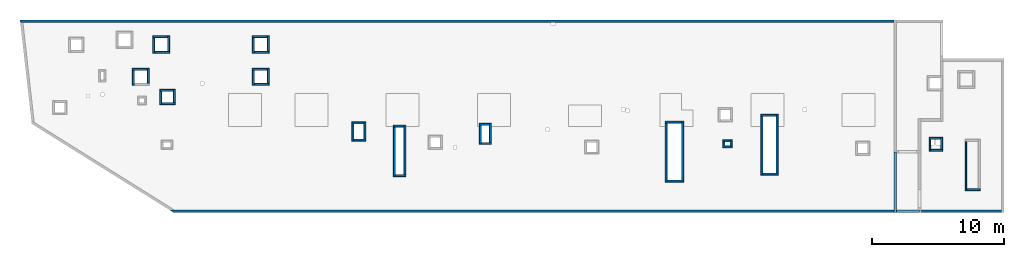
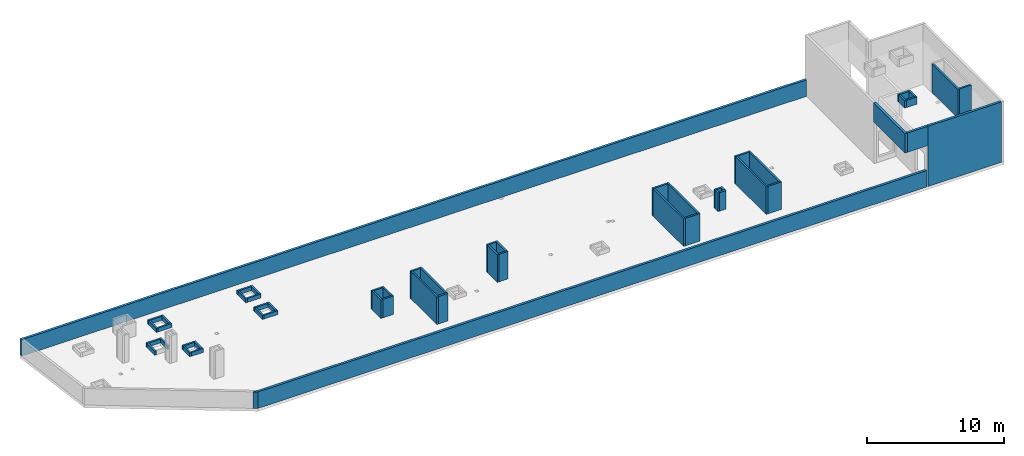
# One storey, part 2 of 3: 54 walls.
"""IFC4 building model written with IfcOpenShell, lengths in millimetres."""

import ifcopenshell
import ifcopenshell.guid

model = None  # the IFC model being written
_history = None  # IfcOwnerHistory: only IFC2X3 demands one
_inside = {}  # id of a spatial element -> (the spatial element, [elements in it])
_under = {}  # id of a project, library or spatial element -> (it, [spatial elements below it])
_declared = {}  # id of a project -> (the project, [libraries it declares])
_typed = {}  # id of a type object -> (the type object, [elements of that type])
_made_of = {}  # id of a material, layer set ... -> (it, [elements and type objects made of it])


def new_model(schema):
    """Start an empty IFC model of exactly this schema.

    Asked for "IFC4X3", IfcOpenShell would pick the latest addendum, in which some entities
    have other attributes; the version numbers below select the first issue.
    IFC2X3 requires an IfcOwnerHistory on every rooted entity: one is made here for all.
    """
    global model, _history
    if schema == "IFC4X3":
        model = ifcopenshell.file(schema_version=(4, 3, 0, 0))
    else:
        model = ifcopenshell.file(schema=schema)
    _inside.clear()
    _under.clear()
    _declared.clear()
    _typed.clear()
    _made_of.clear()
    _history = None
    if model.schema == "IFC2X3":
        org = make("IfcOrganization", Name="unknown")
        user = make(
            "IfcPersonAndOrganization",
            ThePerson=make("IfcPerson", FamilyName="unknown"),
            TheOrganization=org,
        )
        app = make(
            "IfcApplication",
            ApplicationDeveloper=org,
            Version="unknown",
            ApplicationFullName="unknown",
            ApplicationIdentifier="unknown",
        )
        _history = make(
            "IfcOwnerHistory",
            OwningUser=user,
            OwningApplication=app,
            ChangeAction="ADDED",
            CreationDate=0,
        )
    return model


def make(cls, **values):
    """One entity of the class cls with the attributes given. An attribute that is None is left unset."""
    return model.create_entity(
        cls, **{name: value for name, value in values.items() if value is not None}
    )


def entity(cls, *values):
    """Any entity or typed value of the class cls, its attributes in the order of the schema. None: left unset."""
    e = model.create_entity(cls)
    for i, value in enumerate(values):
        if value is not None:
            e[i] = value
    return e


def rooted(cls, **values):
    """An entity with a GlobalId (a new one), such as an element, a storey or a relation."""
    return make(cls, GlobalId=ifcopenshell.guid.new(), OwnerHistory=_history, **values)


def si_unit(unit_type, name, prefix=None):
    """IfcSIUnit, for example si_unit("LENGTHUNIT", "METRE", prefix="MILLI")."""
    return make("IfcSIUnit", UnitType=unit_type, Prefix=prefix, Name=name)


def converted_unit(unit_type, name, factor, base, dimensions=None, offset=None):
    """IfcConversionBasedUnit, such as the inch: factor (a typed value) times the base unit."""
    return make(
        "IfcConversionBasedUnit"
        if offset is None
        else "IfcConversionBasedUnitWithOffset",
        ConversionOffset=offset,
        Dimensions=None
        if dimensions is None
        else entity("IfcDimensionalExponents", *dimensions),
        UnitType=unit_type,
        Name=name,
        ConversionFactor=make(
            "IfcMeasureWithUnit", ValueComponent=factor, UnitComponent=base
        ),
    )


def derived_unit(unit_type, elements):
    """IfcDerivedUnit: a product of units, each with its exponent."""
    return make(
        "IfcDerivedUnit",
        Elements=[
            make("IfcDerivedUnitElement", Unit=unit, Exponent=power)
            for unit, power in elements
        ],
        UnitType=unit_type,
    )


def assignment(units):
    """IfcUnitAssignment: the units of a project."""
    return None if units is None else make("IfcUnitAssignment", Units=units)


def point(xyz):
    """IfcCartesianPoint."""
    return None if xyz is None else make("IfcCartesianPoint", Coordinates=xyz)


def direction(xyz):
    """IfcDirection."""
    return None if xyz is None else make("IfcDirection", DirectionRatios=xyz)


def frame(location, z_axis=None, x_axis=None):
    """IfcAxis2Placement3D, a coordinate frame: its origin and axes. An axis left out is left unset."""
    return make(
        "IfcAxis2Placement3D",
        Location=point(location),
        Axis=direction(z_axis),
        RefDirection=direction(x_axis),
    )


def origin():
    """The frame at (0, 0, 0) with its axes left unset."""
    return frame((0.0, 0.0, 0.0))


def place(relative_to, where):
    """IfcLocalPlacement: puts the frame where relative to a parent placement (None: the world)."""
    return make(
        "IfcLocalPlacement", PlacementRelTo=relative_to, RelativePlacement=where
    )


def context(
    kind, dimensions, precision=None, world=None, true_north=None, identifier=None
):
    """IfcGeometricRepresentationContext, for example the 3D "Model" context."""
    return make(
        "IfcGeometricRepresentationContext",
        ContextIdentifier=identifier,
        ContextType=kind,
        CoordinateSpaceDimension=dimensions,
        Precision=precision,
        WorldCoordinateSystem=world,
        TrueNorth=true_north,
    )


def subcontext(parent, identifier, kind, view, scale=None):
    """IfcGeometricRepresentationSubContext, for example "Body" below "Model"."""
    return make(
        "IfcGeometricRepresentationSubContext",
        ContextIdentifier=identifier,
        ContextType=kind,
        ParentContext=parent,
        TargetScale=scale,
        TargetView=view,
    )


def project(units=None, contexts=None):
    """IfcProject with its units and contexts."""
    return rooted(
        "IfcProject",
        Name="project",
        RepresentationContexts=contexts,
        UnitsInContext=assignment(units),
    )


def spatial(cls, under=None, at=None, **own):
    """A site, building, storey or space (cls), placed at a placement, below another one or the project."""
    s = rooted(cls, ObjectPlacement=at, **own)
    if under is not None:
        _under.setdefault(under.id(), (under, []))[1].append(s)
    return s


def point_list(points):
    """IfcCartesianPointList2D or 3D."""
    cls = (
        "IfcCartesianPointList2D" if len(points[0]) == 2 else "IfcCartesianPointList3D"
    )
    return make(cls, CoordList=points)


def indexed_curve(points, segments=None, self_intersect=None):
    """IfcIndexedPolyCurve: lines and arcs through numbered points (the first is 1)."""
    return make(
        "IfcIndexedPolyCurve",
        Points=point_list(points),
        Segments=segments,
        SelfIntersect=self_intersect,
    )


def outline(outer, holes=None, kind="AREA"):
    """IfcArbitraryClosedProfileDef: a profile drawn as a closed curve; with holes, ...WithVoids."""
    if holes is None:
        return make("IfcArbitraryClosedProfileDef", ProfileType=kind, OuterCurve=outer)
    return make(
        "IfcArbitraryProfileDefWithVoids",
        ProfileType=kind,
        OuterCurve=outer,
        InnerCurves=holes,
    )


def extrude(swept, where, along, depth):
    """IfcExtrudedAreaSolid: the profile swept, set in the frame where, extruded along a direction by depth."""
    return make(
        "IfcExtrudedAreaSolid",
        SweptArea=swept,
        Position=where,
        ExtrudedDirection=direction(along),
        Depth=depth,
    )


def shape(context_of_items, identifier, shape_type, items):
    """IfcShapeRepresentation: the items that make up one representation, for example the "Body"."""
    return make(
        "IfcShapeRepresentation",
        ContextOfItems=context_of_items,
        RepresentationIdentifier=identifier,
        RepresentationType=shape_type,
        Items=items,
    )


def material(Name=None, Category=None):
    """IfcMaterial."""
    return make("IfcMaterial", Name=Name, Category=Category)


def made_of(thing, what):
    """Note that an element or type object is made of a material, layer set ...; save() writes the relation."""
    if what is not None:
        _made_of.setdefault(what.id(), (what, []))[1].append(thing)
    return thing


def type_object(cls, material=None, **own):
    """A type object (cls), such as IfcWallType, which elements share."""
    return made_of(rooted(cls, **own), material)


def element(
    cls,
    number,
    at=None,
    inside=None,
    cuts=None,
    type_object=None,
    material=None,
    context=None,
    identifier="Body",
    shape_type=None,
    held_by="IfcProductDefinitionShape",
    body=None,
    shapes=None,
    **own,
):
    """One element of the class cls, such as IfcWall. Its Tag is "e" and its number.

    at: its placement. inside: the storey or other place that contains it. cuts: it is an
    opening in that element (IfcRelVoidsElement). A single representation is given by context,
    identifier, shape_type and body (its items); several are given by shapes. held_by: the class
    of the entity that holds the representations. save() writes the other relations.
    """
    e = rooted(cls, Tag="e%d" % number, ObjectPlacement=at, **own)
    if body is not None:
        shapes = [shape(context, identifier, shape_type, body)]
    if shapes is not None:
        e.Representation = make(held_by, Representations=shapes)
    if inside is not None:
        _inside.setdefault(inside.id(), (inside, []))[1].append(e)
    if cuts is not None:
        rooted(
            "IfcRelVoidsElement", RelatingBuildingElement=cuts, RelatedOpeningElement=e
        )
    if type_object is not None:
        _typed.setdefault(type_object.id(), (type_object, []))[1].append(e)
    return made_of(e, material)


def aggregate(whole, parts):
    """IfcRelAggregates: a whole, such as a stair, and the parts it consists of."""
    return rooted("IfcRelAggregates", RelatingObject=whole, RelatedObjects=parts)


def save(model, path):
    """Write the relations noted so far, then the file.

    IfcRelAggregates (storeys below a building ...), IfcRelContainedInSpatialStructure (elements
    in a storey), IfcRelDefinesByType, IfcRelAssociatesMaterial and IfcRelDeclares: one each for
    every whole, place, type object, material and project.
    """
    for whole, parts in _under.values():
        aggregate(whole, parts)
    for where, things in _inside.values():
        rooted(
            "IfcRelContainedInSpatialStructure",
            RelatedElements=things,
            RelatingStructure=where,
        )
    for kind, things in _typed.values():
        rooted("IfcRelDefinesByType", RelatedObjects=things, RelatingType=kind)
    for what, things in _made_of.values():
        rooted("IfcRelAssociatesMaterial", RelatedObjects=things, RelatingMaterial=what)
    for by, libraries in _declared.values():
        rooted("IfcRelDeclares", RelatingContext=by, RelatedDefinitions=libraries)
    model.write(path)


model = new_model("IFC4")

# Units and contexts
model_context = context("Model", 3, precision=0.01, world=origin(), true_north=direction((6.12303176911189e-17, 1.0)))
plan_context = context("Plan", 3, precision=0.01, world=origin(), true_north=direction((6.12303176911189e-17, 1.0)))
body_context = subcontext(model_context, "Body", "Model", "MODEL_VIEW")
ifc_project = project(units=[si_unit("LENGTHUNIT", "METRE", prefix="MILLI"), si_unit("AREAUNIT", "SQUARE_METRE"), si_unit("VOLUMEUNIT", "CUBIC_METRE"), converted_unit("PLANEANGLEUNIT", "DEGREE", entity("IfcRatioMeasure", 0.0174532925199433), si_unit("PLANEANGLEUNIT", "RADIAN"), dimensions=[0, 0, 0, 0, 0, 0, 0]), si_unit("MASSUNIT", "GRAM", prefix="KILO"), derived_unit("MASSDENSITYUNIT", [(si_unit("MASSUNIT", "GRAM", prefix="KILO"), 1), (si_unit("LENGTHUNIT", "METRE"), -3)]), derived_unit("MOMENTOFINERTIAUNIT", [(si_unit("LENGTHUNIT", "METRE"), 4)]), si_unit("TIMEUNIT", "SECOND"), si_unit("FREQUENCYUNIT", "HERTZ"), si_unit("THERMODYNAMICTEMPERATUREUNIT", "DEGREE_CELSIUS"), derived_unit("THERMALTRANSMITTANCEUNIT", [(si_unit("MASSUNIT", "GRAM", prefix="KILO"), 1), (si_unit("THERMODYNAMICTEMPERATUREUNIT", "KELVIN"), -1), (si_unit("TIMEUNIT", "SECOND"), -3)]), derived_unit("VOLUMETRICFLOWRATEUNIT", [(si_unit("LENGTHUNIT", "METRE"), 3), (si_unit("TIMEUNIT", "SECOND"), -1)]), derived_unit("MASSFLOWRATEUNIT", [(si_unit("MASSUNIT", "GRAM", prefix="KILO"), 1), (si_unit("TIMEUNIT", "SECOND"), -1)]), derived_unit("ROTATIONALFREQUENCYUNIT", [(si_unit("TIMEUNIT", "SECOND"), -1)]), si_unit("ELECTRICCURRENTUNIT", "AMPERE"), si_unit("ELECTRICVOLTAGEUNIT", "VOLT"), si_unit("POWERUNIT", "WATT"), si_unit("FORCEUNIT", "NEWTON", prefix="KILO"), si_unit("ILLUMINANCEUNIT", "LUX"), si_unit("LUMINOUSFLUXUNIT", "LUMEN"), si_unit("LUMINOUSINTENSITYUNIT", "CANDELA"), derived_unit("USERDEFINED", [(si_unit("MASSUNIT", "GRAM", prefix="KILO"), -1), (si_unit("LENGTHUNIT", "METRE"), -2), (si_unit("TIMEUNIT", "SECOND"), 3), (si_unit("LUMINOUSFLUXUNIT", "LUMEN"), 1)]), derived_unit("LINEARVELOCITYUNIT", [(si_unit("LENGTHUNIT", "METRE"), 1), (si_unit("TIMEUNIT", "SECOND"), -1)]), si_unit("PRESSUREUNIT", "PASCAL"), derived_unit("USERDEFINED", [(si_unit("LENGTHUNIT", "METRE"), -2), (si_unit("MASSUNIT", "GRAM", prefix="KILO"), 1), (si_unit("TIMEUNIT", "SECOND"), -2)]), derived_unit("LINEARFORCEUNIT", [(si_unit("MASSUNIT", "GRAM", prefix="KILO"), 1), (si_unit("LENGTHUNIT", "METRE"), 1), (si_unit("TIMEUNIT", "SECOND"), -2), (si_unit("LENGTHUNIT", "METRE"), -1)]), derived_unit("PLANARFORCEUNIT", [(si_unit("MASSUNIT", "GRAM", prefix="KILO"), 1), (si_unit("LENGTHUNIT", "METRE"), 1), (si_unit("TIMEUNIT", "SECOND"), -2), (si_unit("LENGTHUNIT", "METRE"), -2)])], contexts=[model_context, plan_context])

# Site, building, storey
site_placement = place(None, origin())
site = spatial("IfcSite", under=ifc_project, at=site_placement, CompositionType="ELEMENT")
building_placement = place(site_placement, origin())
building = spatial("IfcBuilding", under=site, at=building_placement, CompositionType="ELEMENT")
storey_placement = place(building_placement, frame((0.0, 0.0, 32250.0)))
storey = spatial("IfcBuildingStorey", under=building, at=storey_placement, CompositionType="ELEMENT", Elevation=32250.0)

# Walls
ifc_material = material()
wall_type_1 = type_object("IfcWallType", Name=":ADSK_ 25_200", PredefinedType="STANDARD")
wall_1_placement = place(storey_placement, frame((-892.0, 20400.0, 0.0)))
element("IfcWall", 1, at=wall_1_placement, inside=storey, type_object=wall_type_1, material=ifc_material, Name=":ADSK_ 25_200", ObjectType=":ADSK_ 25_200", PredefinedType="NOTDEFINED", context=body_context, shape_type="SweptSolid", body=[
    extrude(outline(indexed_curve([(66122.0, -99.999999999998), (66122.0, 99.9999999999999), (-5.16850425502453e-14, 99.9999999999989), (22.692092865985, -99.9999999999988), (223.975303985637, -99.9999999999982), (40192.0, -99.9999999999993), (40492.0, -99.9999999999983), (66122.0, -99.999999999998)], self_intersect=False)), origin(), (0.0, 0.0, 1.0), 1470.0),
])
wall_2_placement = place(storey_placement, frame((73370.0, 6030.0, 0.0), z_axis=(0.0, 0.0, 1.0), x_axis=(-1.0, 0.0, 0.0)))
element("IfcWall", 2, at=wall_2_placement, inside=storey, type_object=wall_type_1, material=ifc_material, Name=":ADSK_ 25_200", ObjectType=":ADSK_ 25_200", PredefinedType="NOTDEFINED", context=body_context, shape_type="SweptSolid", body=[
    extrude(outline(indexed_curve([(6189.99918212896, 100.0), (-3.22279133840974e-13, 100.0), (3.22279133840974e-13, -100.0), (6189.99918212896, -99.9999999999995), (6189.99918212896, 100.0)], self_intersect=False)), origin(), (0.0, 0.0, 1.0), 5370.0),
])
wall_3_placement = place(storey_placement, frame((67080.0, 6030.0, 0.0), z_axis=(0.0, 0.0, 1.0), x_axis=(-1.0, 0.0, 0.0)))
element("IfcWall", 3, at=wall_3_placement, inside=storey, type_object=wall_type_1, material=ifc_material, Name=":ADSK_ 25_200", ObjectType=":ADSK_ 25_200", PredefinedType="NOTDEFINED", context=body_context, shape_type="SweptSolid", body=[
    extrude(outline(indexed_curve([(56662.6100905303, -100.0), (56342.5369381647, 99.9999999999997), (-3.22279133840974e-13, 100.0), (3.22279133840974e-13, -100.0), (56285.1888101747, -100.000000000001), (56662.6100905303, -100.0)], self_intersect=False)), origin(), (0.0, 0.0, 1.0), 1470.0),
])
wall_4_placement = place(storey_placement, frame((65330.0, 10525.0, 3650.0), z_axis=(0.0, 0.0, 1.0), x_axis=(0.0, -1.0, 0.0)))
element("IfcWall", 4, at=wall_4_placement, inside=storey, type_object=wall_type_1, material=ifc_material, Name=":ADSK_ 25_200", ObjectType=":ADSK_ 25_200", PredefinedType="NOTDEFINED", context=body_context, shape_type="SweptSolid", body=[
    extrude(outline(indexed_curve([(4595.00000000053, 100.000000000003), (0.0, 100.000000000003), (0.0, -100.000000000003), (4595.00000000053, -100.000000000003), (4595.00000000053, 100.000000000003)], self_intersect=False)), origin(), (0.0, 0.0, 1.0), 1720.0),
])
wall_5_placement = place(storey_placement, frame((65430.0, 6030.0, 3650.0)))
element("IfcWall", 5, at=wall_5_placement, inside=storey, type_object=wall_type_1, material=ifc_material, Name=":ADSK_ 25_200", ObjectType=":ADSK_ 25_200", PredefinedType="NOTDEFINED", context=body_context, shape_type="SweptSolid", body=[
    extrude(outline(indexed_curve([(1749.99999999991, 100.0), (1.66594942968991e-13, 100.0), (-1.66594942968991e-13, -100.0), (1749.99999999991, -99.9999999999997), (1749.99999999991, 100.0)], self_intersect=False)), origin(), (0.0, 0.0, 1.0), 1720.0),
])
wall_type_2 = type_object("IfcWallType", Name=":ADSK_ 25_150", PredefinedType="STANDARD")
wall_6_placement = place(storey_placement, frame((9150.0, 19225.0, 0.0)))
element("IfcWall", 6, at=wall_6_placement, inside=storey, type_object=wall_type_2, material=ifc_material, Name=":ADSK_ 25_150", ObjectType=":ADSK_ 25_150", PredefinedType="NOTDEFINED", context=body_context, shape_type="SweptSolid", body=[
    extrude(outline(indexed_curve([(1150.0, 75.0000000000003), (0.0, 75.0000000000003), (0.0, -75.0000000000003), (1150.0, -75.0000000000003), (1150.0, 75.0000000000003)], self_intersect=False)), origin(), (0.0, 0.0, 1.0), 349.999999999998),
])
wall_7_placement = place(storey_placement, frame((9225.0, 18000.0, 0.0), z_axis=(0.0, 0.0, 1.0), x_axis=(0.0, 1.0, 0.0)))
element("IfcWall", 7, at=wall_7_placement, inside=storey, type_object=wall_type_2, material=ifc_material, Name=":ADSK_ 25_150", ObjectType=":ADSK_ 25_150", PredefinedType="NOTDEFINED", context=body_context, shape_type="SweptSolid", body=[
    extrude(outline(indexed_curve([(1150.00000000001, 75.0000000000003), (0.0, 75.0000000000003), (0.0, -75.0000000000003), (1150.00000000001, -75.0000000000003), (1150.00000000001, 75.0000000000003)], self_intersect=False)), origin(), (0.0, 0.0, 1.0), 349.999999999998),
])
wall_8_placement = place(storey_placement, frame((10450.0, 18075.0, 0.0), z_axis=(0.0, 0.0, 1.0), x_axis=(-1.0, 0.0, 0.0)))
element("IfcWall", 8, at=wall_8_placement, inside=storey, type_object=wall_type_2, material=ifc_material, Name=":ADSK_ 25_150", ObjectType=":ADSK_ 25_150", PredefinedType="NOTDEFINED", context=body_context, shape_type="SweptSolid", body=[
    extrude(outline(indexed_curve([(1150.0, 75.0000000000003), (0.0, 75.0000000000003), (0.0, -75.0000000000003), (1150.0, -75.0000000000003), (1150.0, 75.0000000000003)], self_intersect=False)), origin(), (0.0, 0.0, 1.0), 349.999999999998),
])
wall_9_placement = place(storey_placement, frame((10375.0, 19300.0, 0.0), z_axis=(0.0, 0.0, 1.0), x_axis=(0.0, -1.0, 0.0)))
element("IfcWall", 9, at=wall_9_placement, inside=storey, type_object=wall_type_2, material=ifc_material, Name=":ADSK_ 25_150", ObjectType=":ADSK_ 25_150", PredefinedType="NOTDEFINED", context=body_context, shape_type="SweptSolid", body=[
    extrude(outline(indexed_curve([(1150.00000000001, 75.0000000000003), (0.0, 75.0000000000003), (0.0, -75.0000000000003), (1150.00000000001, -75.0000000000003), (1150.00000000001, 75.0000000000003)], self_intersect=False)), origin(), (0.0, 0.0, 1.0), 349.999999999998),
])
wall_10_placement = place(storey_placement, frame((7600.0, 16775.0, 0.0)))
element("IfcWall", 10, at=wall_10_placement, inside=storey, type_object=wall_type_2, material=ifc_material, Name=":ADSK_ 25_150", ObjectType=":ADSK_ 25_150", PredefinedType="NOTDEFINED", context=body_context, shape_type="SweptSolid", body=[
    extrude(outline(indexed_curve([(1150.0, 75.0000000000003), (0.0, 75.0000000000003), (0.0, -75.0000000000003), (1150.0, -75.0000000000003), (1150.0, 75.0000000000003)], self_intersect=False)), origin(), (0.0, 0.0, 1.0), 349.999999999998),
])
for number, where, z_axis, x_axis, name in (
    (11, (7675.0, 15550.0, 0.0), (0.0, 0.0, 1.0), (0.0, 1.0, 0.0), ":ADSK_ 25_150"),
    (12, (8825.0, 16850.0, 0.0), (0.0, 0.0, 1.0), (0.0, -1.0, 0.0), ":ADSK_ 25_150"),
):
    element("IfcWall", number, at=place(storey_placement, frame(where, z_axis=z_axis, x_axis=x_axis)), inside=storey, type_object=wall_type_2, material=ifc_material, Name=name, ObjectType=":ADSK_ 25_150", PredefinedType="NOTDEFINED", context=body_context, shape_type="SweptSolid", body=[
        extrude(outline(indexed_curve([(1150.0, 75.0000000000003), (0.0, 75.0000000000003), (0.0, -75.0000000000003), (1150.0, -75.0000000000003), (1150.0, 75.0000000000003)], self_intersect=False)), origin(), (0.0, 0.0, 1.0), 349.999999999998),
    ])
wall_11_placement = place(storey_placement, frame((9700.0, 15175.0, 0.0)))
element("IfcWall", 13, at=wall_11_placement, inside=storey, type_object=wall_type_2, material=ifc_material, Name=":ADSK_ 25_150", ObjectType=":ADSK_ 25_150", PredefinedType="NOTDEFINED", context=body_context, shape_type="SweptSolid", body=[
    extrude(outline(indexed_curve([(1000.0, 75.0000000000003), (0.0, 75.0000000000003), (0.0, -75.0000000000003), (1000.0, -75.0000000000003), (1000.0, 75.0000000000003)], self_intersect=False)), origin(), (0.0, 0.0, 1.0), 349.999999999998),
])
wall_12_placement = place(storey_placement, frame((9775.0, 14100.0, 0.0), z_axis=(0.0, 0.0, 1.0), x_axis=(0.0, 1.0, 0.0)))
element("IfcWall", 14, at=wall_12_placement, inside=storey, type_object=wall_type_2, material=ifc_material, Name=":ADSK_ 25_150", ObjectType=":ADSK_ 25_150", PredefinedType="NOTDEFINED", context=body_context, shape_type="SweptSolid", body=[
    extrude(outline(indexed_curve([(999.999999999998, 75.0000000000003), (0.0, 75.0000000000003), (0.0, -75.0000000000003), (999.999999999998, -75.0000000000003), (999.999999999998, 75.0000000000003)], self_intersect=False)), origin(), (0.0, 0.0, 1.0), 349.999999999998),
])
wall_13_placement = place(storey_placement, frame((10850.0, 14175.0, 0.0), z_axis=(0.0, 0.0, 1.0), x_axis=(-1.0, 0.0, 0.0)))
element("IfcWall", 15, at=wall_13_placement, inside=storey, type_object=wall_type_2, material=ifc_material, Name=":ADSK_ 25_150", ObjectType=":ADSK_ 25_150", PredefinedType="NOTDEFINED", context=body_context, shape_type="SweptSolid", body=[
    extrude(outline(indexed_curve([(1000.0, 75.0000000000003), (0.0, 75.0000000000003), (0.0, -75.0000000000003), (1000.0, -75.0000000000003), (1000.0, 75.0000000000003)], self_intersect=False)), origin(), (0.0, 0.0, 1.0), 349.999999999998),
])
wall_14_placement = place(storey_placement, frame((10775.0, 15250.0, 0.0), z_axis=(0.0, 0.0, 1.0), x_axis=(0.0, -1.0, 0.0)))
element("IfcWall", 16, at=wall_14_placement, inside=storey, type_object=wall_type_2, material=ifc_material, Name=":ADSK_ 25_150", ObjectType=":ADSK_ 25_150", PredefinedType="NOTDEFINED", context=body_context, shape_type="SweptSolid", body=[
    extrude(outline(indexed_curve([(999.999999999998, 75.0000000000003), (0.0, 75.0000000000003), (0.0, -75.0000000000003), (999.999999999998, -75.0000000000003), (999.999999999998, 75.0000000000003)], self_intersect=False)), origin(), (0.0, 0.0, 1.0), 349.999999999998),
])
wall_15_placement = place(storey_placement, frame((16670.0, 19225.0, 0.0)))
element("IfcWall", 17, at=wall_15_placement, inside=storey, type_object=wall_type_2, material=ifc_material, Name=":ADSK_ 25_150", ObjectType=":ADSK_ 25_150", PredefinedType="NOTDEFINED", context=body_context, shape_type="SweptSolid", body=[
    extrude(outline(indexed_curve([(1150.0, 75.0000000000003), (0.0, 75.0000000000003), (0.0, -75.0000000000003), (1150.0, -75.0000000000003), (1150.0, 75.0000000000003)], self_intersect=False)), origin(), (0.0, 0.0, 1.0), 349.999999999998),
])
for number, where, z_axis, x_axis, name in (
    (18, (16745.0, 18000.0, 0.0), (0.0, 0.0, 1.0), (0.0, 1.0, 0.0), ":ADSK_ 25_150"),
    (19, (17970.0, 18075.0, 0.0), (0.0, 0.0, 1.0), (-1.0, 0.0, 0.0), ":ADSK_ 25_150"),
    (20, (17895.0, 19300.0, 0.0), (0.0, 0.0, 1.0), (0.0, -1.0, 0.0), ":ADSK_ 25_150"),
):
    element("IfcWall", number, at=place(storey_placement, frame(where, z_axis=z_axis, x_axis=x_axis)), inside=storey, type_object=wall_type_2, material=ifc_material, Name=name, ObjectType=":ADSK_ 25_150", PredefinedType="NOTDEFINED", context=body_context, shape_type="SweptSolid", body=[
        extrude(outline(indexed_curve([(1150.0, 75.0000000000003), (0.0, 75.0000000000003), (0.0, -75.0000000000003), (1150.0, -75.0000000000003), (1150.0, 75.0000000000003)], self_intersect=False)), origin(), (0.0, 0.0, 1.0), 349.999999999998),
    ])
wall_16_placement = place(storey_placement, frame((16670.0, 16775.0, 0.0)))
element("IfcWall", 21, at=wall_16_placement, inside=storey, type_object=wall_type_2, material=ifc_material, Name=":ADSK_ 25_150", ObjectType=":ADSK_ 25_150", PredefinedType="NOTDEFINED", context=body_context, shape_type="SweptSolid", body=[
    extrude(outline(indexed_curve([(1150.0, 75.0000000000003), (0.0, 75.0000000000003), (0.0, -75.0000000000003), (1150.0, -75.0000000000003), (1150.0, 75.0000000000003)], self_intersect=False)), origin(), (0.0, 0.0, 1.0), 349.999999999998),
])
for number, where, z_axis, x_axis, name in (
    (22, (16745.0, 15550.0, 0.0), (0.0, 0.0, 1.0), (0.0, 1.0, 0.0), ":ADSK_ 25_150"),
    (23, (17970.0, 15625.0, 0.0), (0.0, 0.0, 1.0), (-1.0, 0.0, 0.0), ":ADSK_ 25_150"),
    (24, (17895.0, 16850.0, 0.0), (0.0, 0.0, 1.0), (0.0, -1.0, 0.0), ":ADSK_ 25_150"),
):
    element("IfcWall", number, at=place(storey_placement, frame(where, z_axis=z_axis, x_axis=x_axis)), inside=storey, type_object=wall_type_2, material=ifc_material, Name=name, ObjectType=":ADSK_ 25_150", PredefinedType="NOTDEFINED", context=body_context, shape_type="SweptSolid", body=[
        extrude(outline(indexed_curve([(1150.0, 75.0000000000003), (0.0, 75.0000000000003), (0.0, -75.0000000000003), (1150.0, -75.0000000000003), (1150.0, 75.0000000000003)], self_intersect=False)), origin(), (0.0, 0.0, 1.0), 349.999999999998),
    ])
wall_17_placement = place(storey_placement, frame((24225.0, 12715.0, 0.0)))
element("IfcWall", 25, at=wall_17_placement, inside=storey, type_object=wall_type_2, material=ifc_material, Name=":ADSK_ 25_150", ObjectType=":ADSK_ 25_150", PredefinedType="NOTDEFINED", context=body_context, shape_type="SweptSolid", body=[
    extrude(outline(indexed_curve([(899.999999999999, 75.0000000000003), (0.0, 75.0000000000003), (0.0, -75.0000000000003), (899.999999999999, -75.0000000000003), (899.999999999999, 75.0000000000003)], self_intersect=False)), origin(), (0.0, 0.0, 1.0), 1650.00000000001),
])
wall_18_placement = place(storey_placement, frame((24300.0, 11340.0, 0.0), z_axis=(0.0, 0.0, 1.0), x_axis=(0.0, 1.0, 0.0)))
element("IfcWall", 26, at=wall_18_placement, inside=storey, type_object=wall_type_2, material=ifc_material, Name=":ADSK_ 25_150", ObjectType=":ADSK_ 25_150", PredefinedType="NOTDEFINED", context=body_context, shape_type="SweptSolid", body=[
    extrude(outline(indexed_curve([(1300.00000000001, 75.0000000000003), (0.0, 75.0000000000003), (0.0, -75.0000000000003), (1300.00000000001, -75.0000000000003), (1300.00000000001, 75.0000000000003)], self_intersect=False)), origin(), (0.0, 0.0, 1.0), 1650.00000000001),
])
wall_19_placement = place(storey_placement, frame((25275.0, 11415.0, 0.0), z_axis=(0.0, 0.0, 1.0), x_axis=(-1.0, 0.0, 0.0)))
element("IfcWall", 27, at=wall_19_placement, inside=storey, type_object=wall_type_2, material=ifc_material, Name=":ADSK_ 25_150", ObjectType=":ADSK_ 25_150", PredefinedType="NOTDEFINED", context=body_context, shape_type="SweptSolid", body=[
    extrude(outline(indexed_curve([(899.999999999999, 75.0000000000003), (0.0, 75.0000000000003), (0.0, -75.0000000000003), (899.999999999999, -75.0000000000003), (899.999999999999, 75.0000000000003)], self_intersect=False)), origin(), (0.0, 0.0, 1.0), 1650.00000000001),
])
wall_20_placement = place(storey_placement, frame((25200.0, 12790.0, 0.0), z_axis=(0.0, 0.0, 1.0), x_axis=(0.0, -1.0, 0.0)))
element("IfcWall", 28, at=wall_20_placement, inside=storey, type_object=wall_type_2, material=ifc_material, Name=":ADSK_ 25_150", ObjectType=":ADSK_ 25_150", PredefinedType="NOTDEFINED", context=body_context, shape_type="SweptSolid", body=[
    extrude(outline(indexed_curve([(1300.00000000001, 75.0000000000003), (0.0, 75.0000000000003), (0.0, -75.0000000000003), (1300.00000000001, -75.0000000000003), (1300.00000000001, 75.0000000000003)], self_intersect=False)), origin(), (0.0, 0.0, 1.0), 1650.00000000001),
])
wall_21_placement = place(storey_placement, frame((27365.0, 12475.0, 0.0)))
element("IfcWall", 29, at=wall_21_placement, inside=storey, type_object=wall_type_2, material=ifc_material, Name=":ADSK_ 25_150", ObjectType=":ADSK_ 25_150", PredefinedType="NOTDEFINED", context=body_context, shape_type="SweptSolid", body=[
    extrude(outline(indexed_curve([(800.000000000004, 75.0000000000003), (0.0, 75.0000000000003), (0.0, -75.0000000000003), (800.000000000004, -75.0000000000003), (800.000000000004, 75.0000000000003)], self_intersect=False)), origin(), (0.0, 0.0, 1.0), 2450.0),
])
wall_22_placement = place(storey_placement, frame((27440.0, 8650.0, 0.0), z_axis=(0.0, 0.0, 1.0), x_axis=(0.0, 1.0, 0.0)))
element("IfcWall", 30, at=wall_22_placement, inside=storey, type_object=wall_type_2, material=ifc_material, Name=":ADSK_ 25_150", ObjectType=":ADSK_ 25_150", PredefinedType="NOTDEFINED", context=body_context, shape_type="SweptSolid", body=[
    extrude(outline(indexed_curve([(3750.0, 75.0000000000003), (0.0, 75.0000000000003), (0.0, -75.0000000000003), (3750.0, -75.0000000000003), (3750.0, 75.0000000000003)], self_intersect=False)), origin(), (0.0, 0.0, 1.0), 2450.0),
])
wall_23_placement = place(storey_placement, frame((28315.0, 8725.0, 0.0), z_axis=(0.0, 0.0, 1.0), x_axis=(-1.0, 0.0, 0.0)))
element("IfcWall", 31, at=wall_23_placement, inside=storey, type_object=wall_type_2, material=ifc_material, Name=":ADSK_ 25_150", ObjectType=":ADSK_ 25_150", PredefinedType="NOTDEFINED", context=body_context, shape_type="SweptSolid", body=[
    extrude(outline(indexed_curve([(800.000000000004, 75.0000000000003), (0.0, 75.0000000000003), (0.0, -75.0000000000003), (800.000000000004, -75.0000000000003), (800.000000000004, 75.0000000000003)], self_intersect=False)), origin(), (0.0, 0.0, 1.0), 2450.0),
])
wall_24_placement = place(storey_placement, frame((28240.0, 12550.0, 0.0), z_axis=(0.0, 0.0, 1.0), x_axis=(0.0, -1.0, 0.0)))
element("IfcWall", 32, at=wall_24_placement, inside=storey, type_object=wall_type_2, material=ifc_material, Name=":ADSK_ 25_150", ObjectType=":ADSK_ 25_150", PredefinedType="NOTDEFINED", context=body_context, shape_type="SweptSolid", body=[
    extrude(outline(indexed_curve([(3750.0, 75.0000000000003), (0.0, 75.0000000000003), (0.0, -75.0000000000003), (3750.0, -75.0000000000003), (3750.0, 75.0000000000003)], self_intersect=False)), origin(), (0.0, 0.0, 1.0), 2450.0),
])
wall_25_placement = place(storey_placement, frame((33870.0, 12605.0, 0.0)))
element("IfcWall", 33, at=wall_25_placement, inside=storey, type_object=wall_type_2, material=ifc_material, Name=":ADSK_ 25_150", ObjectType=":ADSK_ 25_150", PredefinedType="NOTDEFINED", context=body_context, shape_type="SweptSolid", body=[
    extrude(outline(indexed_curve([(749.999999999998, 75.0000000000003), (0.0, 75.0000000000003), (0.0, -75.0000000000003), (749.999999999998, -75.0000000000003), (749.999999999998, 75.0000000000003)], self_intersect=False)), origin(), (0.0, 0.0, 1.0), 2450.0),
])
wall_26_placement = place(storey_placement, frame((33945.0, 11080.0, 0.0), z_axis=(0.0, 0.0, 1.0), x_axis=(0.0, 1.0, 0.0)))
element("IfcWall", 34, at=wall_26_placement, inside=storey, type_object=wall_type_2, material=ifc_material, Name=":ADSK_ 25_150", ObjectType=":ADSK_ 25_150", PredefinedType="NOTDEFINED", context=body_context, shape_type="SweptSolid", body=[
    extrude(outline(indexed_curve([(1450.0, 75.0000000000003), (0.0, 75.0000000000003), (0.0, -75.0000000000003), (1450.0, -75.0000000000003), (1450.0, 75.0000000000003)], self_intersect=False)), origin(), (0.0, 0.0, 1.0), 2450.0),
])
wall_27_placement = place(storey_placement, frame((34770.0, 11155.0, 0.0), z_axis=(0.0, 0.0, 1.0), x_axis=(-1.0, 0.0, 0.0)))
element("IfcWall", 35, at=wall_27_placement, inside=storey, type_object=wall_type_2, material=ifc_material, Name=":ADSK_ 25_150", ObjectType=":ADSK_ 25_150", PredefinedType="NOTDEFINED", context=body_context, shape_type="SweptSolid", body=[
    extrude(outline(indexed_curve([(749.999999999998, 75.0000000000003), (0.0, 75.0000000000003), (0.0, -75.0000000000003), (749.999999999998, -75.0000000000003), (749.999999999998, 75.0000000000003)], self_intersect=False)), origin(), (0.0, 0.0, 1.0), 2450.0),
])
wall_28_placement = place(storey_placement, frame((34695.0, 12680.0, 0.0), z_axis=(0.0, 0.0, 1.0), x_axis=(0.0, -1.0, 0.0)))
element("IfcWall", 36, at=wall_28_placement, inside=storey, type_object=wall_type_2, material=ifc_material, Name=":ADSK_ 25_150", ObjectType=":ADSK_ 25_150", PredefinedType="NOTDEFINED", context=body_context, shape_type="SweptSolid", body=[
    extrude(outline(indexed_curve([(1450.0, 75.0000000000003), (0.0, 75.0000000000003), (0.0, -75.0000000000003), (1450.0, -75.0000000000003), (1450.0, 75.0000000000003)], self_intersect=False)), origin(), (0.0, 0.0, 1.0), 2450.0),
])
wall_29_placement = place(storey_placement, frame((47920.0, 12765.0, 0.0)))
element("IfcWall", 37, at=wall_29_placement, inside=storey, type_object=wall_type_2, material=ifc_material, Name=":ADSK_ 25_150", ObjectType=":ADSK_ 25_150", PredefinedType="NOTDEFINED", context=body_context, shape_type="SweptSolid", body=[
    extrude(outline(indexed_curve([(1249.99999999999, 75.0000000000003), (0.0, 75.0000000000003), (0.0, -75.0000000000003), (1249.99999999999, -75.0000000000003), (1249.99999999999, 75.0000000000003)], self_intersect=False)), origin(), (0.0, 0.0, 1.0), 2450.0),
])
wall_30_placement = place(storey_placement, frame((47995.0, 8240.0, 0.0), z_axis=(0.0, 0.0, 1.0), x_axis=(0.0, 1.0, 0.0)))
element("IfcWall", 38, at=wall_30_placement, inside=storey, type_object=wall_type_2, material=ifc_material, Name=":ADSK_ 25_150", ObjectType=":ADSK_ 25_150", PredefinedType="NOTDEFINED", context=body_context, shape_type="SweptSolid", body=[
    extrude(outline(indexed_curve([(4450.0, 75.0000000000003), (0.0, 75.0000000000003), (0.0, -75.0000000000003), (4450.0, -75.0000000000003), (4450.0, 75.0000000000003)], self_intersect=False)), origin(), (0.0, 0.0, 1.0), 2450.0),
])
wall_31_placement = place(storey_placement, frame((49320.0, 8315.0, 0.0), z_axis=(0.0, 0.0, 1.0), x_axis=(-1.0, 0.0, 0.0)))
element("IfcWall", 39, at=wall_31_placement, inside=storey, type_object=wall_type_2, material=ifc_material, Name=":ADSK_ 25_150", ObjectType=":ADSK_ 25_150", PredefinedType="NOTDEFINED", context=body_context, shape_type="SweptSolid", body=[
    extrude(outline(indexed_curve([(1249.99999999999, 75.0000000000003), (0.0, 75.0000000000003), (0.0, -75.0000000000003), (1249.99999999999, -75.0000000000003), (1249.99999999999, 75.0000000000003)], self_intersect=False)), origin(), (0.0, 0.0, 1.0), 2450.0),
])
wall_32_placement = place(storey_placement, frame((49245.0, 12840.0, 0.0), z_axis=(0.0, 0.0, 1.0), x_axis=(0.0, -1.0, 0.0)))
element("IfcWall", 40, at=wall_32_placement, inside=storey, type_object=wall_type_2, material=ifc_material, Name=":ADSK_ 25_150", ObjectType=":ADSK_ 25_150", PredefinedType="NOTDEFINED", context=body_context, shape_type="SweptSolid", body=[
    extrude(outline(indexed_curve([(4450.0, 75.0000000000003), (0.0, 75.0000000000003), (0.0, -75.0000000000003), (4450.0, -75.0000000000003), (4450.0, 75.0000000000003)], self_intersect=False)), origin(), (0.0, 0.0, 1.0), 2450.0),
])
wall_33_placement = place(storey_placement, frame((52300.0, 11350.0, 0.0)))
element("IfcWall", 41, at=wall_33_placement, inside=storey, type_object=wall_type_2, material=ifc_material, Name=":ADSK_ 25_150", ObjectType=":ADSK_ 25_150", PredefinedType="NOTDEFINED", context=body_context, shape_type="SweptSolid", body=[
    extrude(outline(indexed_curve([(550.000000000014, 75.0000000000003), (0.0, 75.0000000000003), (0.0, -75.0000000000003), (550.000000000014, -75.0000000000003), (550.000000000014, 75.0000000000003)], self_intersect=False)), origin(), (0.0, 0.0, 1.0), 1650.00000000001),
])
wall_34_placement = place(storey_placement, frame((52375.0, 10825.0, 0.0), z_axis=(0.0, 0.0, 1.0), x_axis=(0.0, 1.0, 0.0)))
element("IfcWall", 42, at=wall_34_placement, inside=storey, type_object=wall_type_2, material=ifc_material, Name=":ADSK_ 25_150", ObjectType=":ADSK_ 25_150", PredefinedType="NOTDEFINED", context=body_context, shape_type="SweptSolid", body=[
    extrude(outline(indexed_curve([(450.000000000006, 75.0000000000003), (0.0, 75.0000000000003), (0.0, -75.0000000000003), (450.000000000006, -75.0000000000003), (450.000000000006, 75.0000000000003)], self_intersect=False)), origin(), (0.0, 0.0, 1.0), 1650.00000000001),
])
wall_35_placement = place(storey_placement, frame((53000.0, 10900.0, 0.0), z_axis=(0.0, 0.0, 1.0), x_axis=(-1.0, 0.0, 0.0)))
element("IfcWall", 43, at=wall_35_placement, inside=storey, type_object=wall_type_2, material=ifc_material, Name=":ADSK_ 25_150", ObjectType=":ADSK_ 25_150", PredefinedType="NOTDEFINED", context=body_context, shape_type="SweptSolid", body=[
    extrude(outline(indexed_curve([(550.000000000014, 75.0000000000003), (0.0, 75.0000000000003), (0.0, -75.0000000000003), (550.000000000014, -75.0000000000003), (550.000000000014, 75.0000000000003)], self_intersect=False)), origin(), (0.0, 0.0, 1.0), 1650.00000000001),
])
wall_36_placement = place(storey_placement, frame((52925.0, 11425.0, 0.0), z_axis=(0.0, 0.0, 1.0), x_axis=(0.0, -1.0, 0.0)))
element("IfcWall", 44, at=wall_36_placement, inside=storey, type_object=wall_type_2, material=ifc_material, Name=":ADSK_ 25_150", ObjectType=":ADSK_ 25_150", PredefinedType="NOTDEFINED", context=body_context, shape_type="SweptSolid", body=[
    extrude(outline(indexed_curve([(450.000000000006, 75.0000000000003), (0.0, 75.0000000000003), (0.0, -75.0000000000003), (450.000000000006, -75.0000000000003), (450.000000000006, 75.0000000000003)], self_intersect=False)), origin(), (0.0, 0.0, 1.0), 1650.00000000001),
])
wall_37_placement = place(storey_placement, frame((55170.0, 13285.0, 0.0)))
element("IfcWall", 45, at=wall_37_placement, inside=storey, type_object=wall_type_2, material=ifc_material, Name=":ADSK_ 25_150", ObjectType=":ADSK_ 25_150", PredefinedType="NOTDEFINED", context=body_context, shape_type="SweptSolid", body=[
    extrude(outline(indexed_curve([(1150.0, 75.0000000000003), (0.0, 75.0000000000003), (0.0, -75.0000000000003), (1150.0, -75.0000000000003), (1150.0, 75.0000000000003)], self_intersect=False)), origin(), (0.0, 0.0, 1.0), 2450.0),
])
wall_38_placement = place(storey_placement, frame((55245.0, 8760.0, 0.0), z_axis=(0.0, 0.0, 1.0), x_axis=(0.0, 1.0, 0.0)))
element("IfcWall", 46, at=wall_38_placement, inside=storey, type_object=wall_type_2, material=ifc_material, Name=":ADSK_ 25_150", ObjectType=":ADSK_ 25_150", PredefinedType="NOTDEFINED", context=body_context, shape_type="SweptSolid", body=[
    extrude(outline(indexed_curve([(4450.0, 75.0000000000003), (0.0, 75.0000000000003), (0.0, -75.0000000000003), (4450.0, -75.0000000000003), (4450.0, 75.0000000000003)], self_intersect=False)), origin(), (0.0, 0.0, 1.0), 2450.0),
])
wall_39_placement = place(storey_placement, frame((56470.0, 8835.0, 0.0), z_axis=(0.0, 0.0, 1.0), x_axis=(-1.0, 0.0, 0.0)))
element("IfcWall", 47, at=wall_39_placement, inside=storey, type_object=wall_type_2, material=ifc_material, Name=":ADSK_ 25_150", ObjectType=":ADSK_ 25_150", PredefinedType="NOTDEFINED", context=body_context, shape_type="SweptSolid", body=[
    extrude(outline(indexed_curve([(1150.0, 75.0000000000003), (0.0, 75.0000000000003), (0.0, -75.0000000000003), (1150.0, -75.0000000000003), (1150.0, 75.0000000000003)], self_intersect=False)), origin(), (0.0, 0.0, 1.0), 2450.0),
])
wall_40_placement = place(storey_placement, frame((56395.0, 13360.0, 0.0), z_axis=(0.0, 0.0, 1.0), x_axis=(0.0, -1.0, 0.0)))
element("IfcWall", 48, at=wall_40_placement, inside=storey, type_object=wall_type_2, material=ifc_material, Name=":ADSK_ 25_150", ObjectType=":ADSK_ 25_150", PredefinedType="NOTDEFINED", context=body_context, shape_type="SweptSolid", body=[
    extrude(outline(indexed_curve([(4450.0, 75.0000000000003), (0.0, 75.0000000000003), (0.0, -75.0000000000003), (4450.0, -75.0000000000003), (4450.0, 75.0000000000003)], self_intersect=False)), origin(), (0.0, 0.0, 1.0), 2450.0),
])
wall_41_placement = place(storey_placement, frame((70695.0, 7565.0, 3900.0), z_axis=(0.0, 0.0, 1.0), x_axis=(0.0, 1.0, 0.0)))
element("IfcWall", 49, at=wall_41_placement, inside=storey, type_object=wall_type_2, material=ifc_material, Name=":ADSK_ 25_150", ObjectType=":ADSK_ 25_150", PredefinedType="NOTDEFINED", context=body_context, shape_type="SweptSolid", body=[
    extrude(outline(indexed_curve([(3750.0, 75.0000000000003), (0.0, 75.0000000000003), (0.0, -75.0000000000003), (3750.0, -75.0000000000003), (3750.0, 75.0000000000003)], self_intersect=False)), origin(), (0.0, 0.0, 1.0), 2550.0),
])
wall_42_placement = place(storey_placement, frame((71770.0, 7640.0, 3900.0), z_axis=(0.0, 0.0, 1.0), x_axis=(-1.0, 0.0, 0.0)))
element("IfcWall", 50, at=wall_42_placement, inside=storey, type_object=wall_type_2, material=ifc_material, Name=":ADSK_ 25_150", ObjectType=":ADSK_ 25_150", PredefinedType="NOTDEFINED", context=body_context, shape_type="SweptSolid", body=[
    extrude(outline(indexed_curve([(999.999999999998, 75.0000000000007), (-1.16021478139113e-13, 75.0000000000003), (1.16021478139113e-13, -75.0000000000003), (999.999999999998, -74.9999999999998), (999.999999999998, 75.0000000000007)], self_intersect=False)), origin(), (0.0, 0.0, 1.0), 2550.0),
])
wall_43_placement = place(storey_placement, frame((67895.0, 11560.0, 3900.0)))
element("IfcWall", 51, at=wall_43_placement, inside=storey, type_object=wall_type_2, material=ifc_material, Name=":ADSK_ 25_150", ObjectType=":ADSK_ 25_150", PredefinedType="NOTDEFINED", context=body_context, shape_type="SweptSolid", body=[
    extrude(outline(indexed_curve([(900.000000000003, 75.0000000000003), (0.0, 75.0000000000003), (0.0, -75.0000000000003), (900.000000000003, -75.0000000000003), (900.000000000003, 75.0000000000003)], self_intersect=False)), origin(), (0.0, 0.0, 1.0), 650.0),
])
wall_44_placement = place(storey_placement, frame((67970.0, 10585.0, 3900.0), z_axis=(0.0, 0.0, 1.0), x_axis=(0.0, 1.0, 0.0)))
element("IfcWall", 52, at=wall_44_placement, inside=storey, type_object=wall_type_2, material=ifc_material, Name=":ADSK_ 25_150", ObjectType=":ADSK_ 25_150", PredefinedType="NOTDEFINED", context=body_context, shape_type="SweptSolid", body=[
    extrude(outline(indexed_curve([(900.000000000001, 75.0000000000003), (0.0, 75.0000000000003), (0.0, -75.0000000000003), (900.000000000001, -75.0000000000003), (900.000000000001, 75.0000000000003)], self_intersect=False)), origin(), (0.0, 0.0, 1.0), 650.0),
])
wall_45_placement = place(storey_placement, frame((68945.0, 10660.0, 3900.0), z_axis=(0.0, 0.0, 1.0), x_axis=(-1.0, 0.0, 0.0)))
element("IfcWall", 53, at=wall_45_placement, inside=storey, type_object=wall_type_2, material=ifc_material, Name=":ADSK_ 25_150", ObjectType=":ADSK_ 25_150", PredefinedType="NOTDEFINED", context=body_context, shape_type="SweptSolid", body=[
    extrude(outline(indexed_curve([(900.000000000003, 75.0000000000003), (0.0, 75.0000000000003), (0.0, -75.0000000000003), (900.000000000003, -75.0000000000003), (900.000000000003, 75.0000000000003)], self_intersect=False)), origin(), (0.0, 0.0, 1.0), 650.0),
])
wall_46_placement = place(storey_placement, frame((68870.0, 11635.0, 3900.0), z_axis=(0.0, 0.0, 1.0), x_axis=(0.0, -1.0, 0.0)))
element("IfcWall", 54, at=wall_46_placement, inside=storey, type_object=wall_type_2, material=ifc_material, Name=":ADSK_ 25_150", ObjectType=":ADSK_ 25_150", PredefinedType="NOTDEFINED", context=body_context, shape_type="SweptSolid", body=[
    extrude(outline(indexed_curve([(900.000000000001, 75.0000000000003), (0.0, 75.0000000000003), (0.0, -75.0000000000003), (900.000000000001, -75.0000000000003), (900.000000000001, 75.0000000000003)], self_intersect=False)), origin(), (0.0, 0.0, 1.0), 650.0),
])

save(model, "model.ifc")
